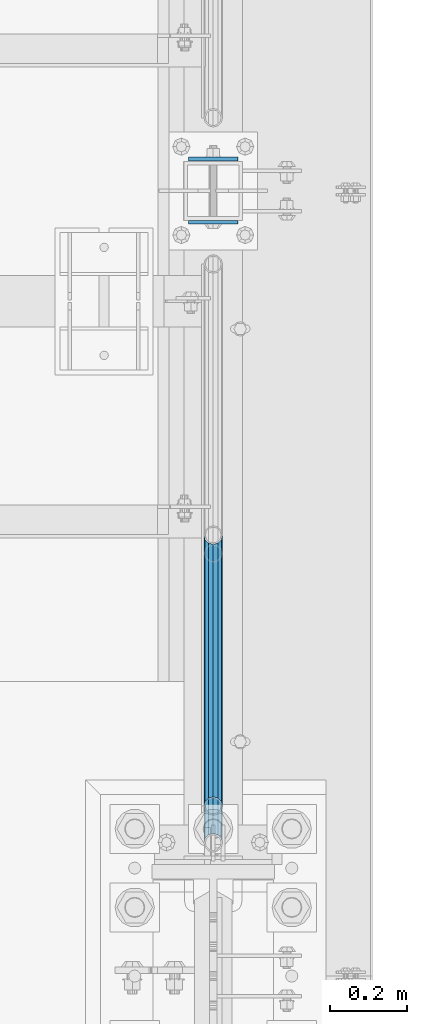
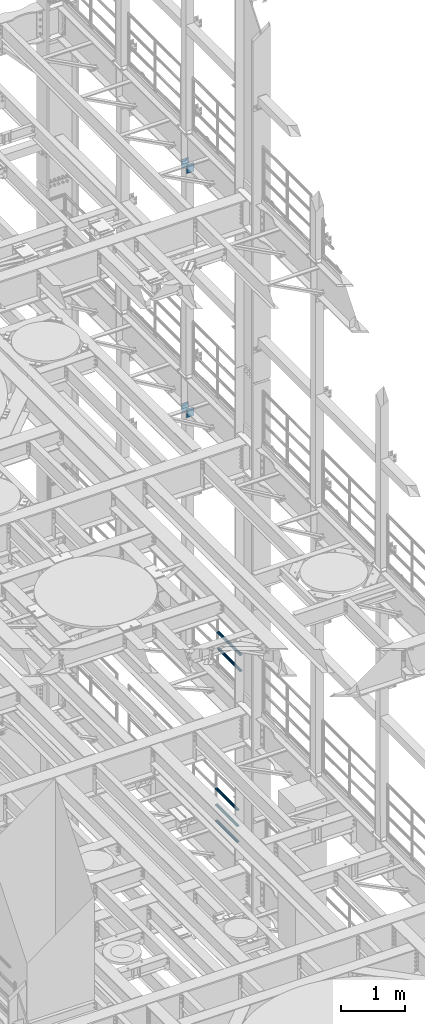
# One storey, part 1342 of 1876: 9 beams, 4 elements without a shape of their own.
"""IFC2X3 building model written with IfcOpenShell, lengths in millimetres."""

from ifc_helpers import new_model, si_unit, frame, origin_with_axes, place, context, subcontext, project, spatial, faceted_brep, material, type_object, element, aggregate, save


model = new_model("IFC2X3")

# Units and contexts
model_context = context("Model", 3, precision=1e-05, world=origin_with_axes())
body_context = subcontext(model_context, "Body", "Model", "MODEL_VIEW")
ifc_project = project(units=[si_unit("LENGTHUNIT", "METRE", prefix="MILLI"), si_unit("AREAUNIT", "SQUARE_METRE"), si_unit("VOLUMEUNIT", "CUBIC_METRE"), si_unit("MASSUNIT", "GRAM", prefix="KILO"), si_unit("TIMEUNIT", "SECOND"), si_unit("PLANEANGLEUNIT", "RADIAN"), si_unit("SOLIDANGLEUNIT", "STERADIAN"), si_unit("THERMODYNAMICTEMPERATUREUNIT", "DEGREE_CELSIUS"), si_unit("LUMINOUSINTENSITYUNIT", "LUMEN")], contexts=[model_context])

# Site, building, storey
site_placement = place(None, origin_with_axes())
site = spatial("IfcSite", under=ifc_project, at=site_placement, CompositionType="ELEMENT")
building_placement = place(site_placement, origin_with_axes())
building = spatial("IfcBuilding", under=site, at=building_placement, Name="Undefined", CompositionType="ELEMENT")
storey_placement = place(building_placement, origin_with_axes())
storey = spatial("IfcBuildingStorey", under=building, at=storey_placement, Name="Undefined", CompositionType="ELEMENT", Elevation=0.0)

# Assembly, beams
assembly_1_placement = place(storey_placement, origin_with_axes())
assembly_1 = element("IfcElementAssembly", 1, at=assembly_1_placement, inside=storey, Name="RAIL", AssemblyPlace="NOTDEFINED", PredefinedType="RIGID_FRAME")
ifc_material_1 = material()
beam_type_1 = type_object("IfcBeamType", Name="PIPE1-1/2SCH40", PredefinedType="NOTDEFINED")
beam_1_placement = place(assembly_1_placement, frame((7620.0, 7964.805, 8620.125), z_axis=(0.0, 0.0, -1.0), x_axis=(0.0, 1.0, 0.0)))
beam_1 = element("IfcBeam", 2, at=beam_1_placement, type_object=beam_type_1, material=ifc_material_1, Name="RAIL", ObjectType="PIPE1-1/2SCH40", context=body_context, shape_type="Brep", body=[
    faceted_brep([(0.0, 24.1299999999992, 0.0), (12.0650000000064, 20.8971929933177, -12.0649999999987), (12.0650000000064, 20.8971929933177, 12.0649999999987), (12.0650000000064, -20.8971929933177, 12.0649999999987), (12.0650000000064, -20.8971929933177, -12.0649999999987), (0.0, -24.1299999999992, 0.0), (20.8971929933249, -12.0650000000005, 20.8971929933177), (20.8971929933249, -12.0650000000005, 15.8661214311796), (15.2545715621445, -17.7076214311801, 10.2235000000001), (12.5151929933249, -20.4470000000001, 0.0), (15.2545715621445, -17.7076214311801, -10.2235000000001), (20.8971929933249, -12.0650000000005, -15.8661214311796), (20.8971929933249, -12.0650000000005, -20.8971929933177), (24.1300000000063, 0.0, -20.4470000000001), (24.1300000000063, 0.0, -24.130000000001), (21.3906214311868, -10.2235000000001, -17.7076214311819), (21.3906214311868, 10.2235000000001, -17.7076214311819), (20.8971929933249, 12.0650000000005, -15.8661214311796), (20.8971929933249, 12.0650000000005, -20.8971929933177), (15.2545715621445, 17.7076214311801, -10.2235000000001), (12.5151929933249, 20.4470000000001, 0.0), (15.2545715621445, 17.7076214311801, 10.2235000000001), (20.8971929933249, 12.0650000000005, 15.8661214311796), (20.8971929933249, 12.0650000000005, 20.8971929933177), (21.3906214311868, 10.2235000000001, 17.7076214311819), (24.1300000000064, 0.0, 20.4470000000001), (24.1300000000064, 0.0, 24.130000000001), (21.3906214311868, -10.2235000000001, 17.7076214311819), (748.982500000002, 24.1300000000001, 0.0), (736.917500000002, 20.8971929933186, -12.0649999999987), (728.085307006683, 12.0649999999996, -20.8971929933177), (748.982500000002, -24.1300000000001, 0.0), (736.917500000002, -20.8971929933186, -12.0649999999987), (736.917500000002, -20.8971929933186, 12.0649999999987), (728.085307006683, -12.0649999999996, 20.8971929933177), (728.085307006683, -12.0649999999996, -20.8971929933177), (724.852500000002, 0.0, -24.130000000001), (727.591878568821, 10.2235000000001, -17.7076214311819), (724.852500000002, 0.0, -20.4470000000001), (728.085307006683, 12.0649999999996, -15.8661214311796), (728.085307006683, -12.0649999999996, -15.8661214311796), (727.591878568821, -10.2235000000001, -17.7076214311819), (733.727928437864, -17.7076214311801, -10.2235000000001), (736.467307006683, -20.4470000000001, 0.0), (733.727928437864, -17.7076214311801, 10.2235000000001), (728.085307006683, -12.0649999999996, 15.8661214311796), (727.591878568821, -10.2235000000001, 17.7076214311819), (724.852500000002, 0.0, 20.4470000000001), (724.852500000002, 0.0, 24.130000000001), (728.085307006683, 12.0649999999996, 20.8971929933177), (736.917500000002, 20.8971929933186, 12.0649999999987), (728.085307006683, 12.0649999999996, 15.8661214311796), (733.727928437864, 17.7076214311801, 10.2235000000001), (736.467307006683, 20.4470000000001, 0.0), (733.727928437864, 17.7076214311801, -10.2235000000001), (727.591878568821, 10.2235000000001, 17.7076214311819)], [[[0, 1, 2]], [[3, 4, 5]], [[6, 7, 8, 9, 10, 11, 12, 4, 3]], [[13, 14, 12, 11, 15]], [[16, 17, 18, 14, 13]], [[2, 1, 18, 17, 19, 20, 21, 22, 23]], [[23, 22, 24, 25, 26]], [[26, 25, 27, 7, 6]], [[1, 0, 28, 29]], [[18, 1, 29, 30]], [[31, 32, 33]], [[6, 3, 33, 34]], [[3, 5, 31, 33]], [[5, 4, 32, 31]], [[4, 12, 35, 32]], [[12, 14, 36, 35]], [[14, 18, 30, 36]], [[37, 38, 36, 30, 39]], [[40, 35, 36, 38, 41]], [[33, 32, 35, 40, 42, 43, 44, 45, 34]], [[34, 45, 46, 47, 48]], [[26, 6, 34, 48]], [[2, 23, 49, 50]], [[23, 26, 48, 49]], [[0, 2, 50, 28]], [[28, 50, 29]], [[49, 51, 52, 53, 54, 39, 30, 29, 50]], [[48, 47, 55, 51, 49]], [[25, 24, 55, 47]], [[55, 24, 22, 21, 52, 51]], [[21, 20, 53, 52]], [[20, 19, 54, 53]], [[19, 17, 16, 37, 39, 54]], [[16, 13, 38, 37]], [[13, 15, 41, 38]], [[41, 15, 11, 10, 42, 40]], [[10, 9, 43, 42]], [[9, 8, 44, 43]], [[8, 7, 27, 46, 45, 44]], [[27, 25, 47, 46]]]),
])
beam_2_placement = place(assembly_1_placement, frame((7620.0, 7964.805, 8924.925), z_axis=(0.0, 0.0, -1.0), x_axis=(0.0, 1.0, 0.0)))
beam_2 = element("IfcBeam", 3, at=beam_2_placement, type_object=beam_type_1, material=ifc_material_1, Name="RAIL", ObjectType="PIPE1-1/2SCH40", context=body_context, shape_type="Brep", body=[
    faceted_brep([(0.0, 24.1299999999992, 0.0), (12.0650000000064, 20.8971929933177, -12.0649999999987), (12.0650000000064, 20.8971929933177, 12.0649999999987), (12.0650000000064, -20.8971929933177, 12.0649999999987), (12.0650000000064, -20.8971929933177, -12.0649999999987), (0.0, -24.1299999999992, 0.0), (20.8971929933249, -12.0650000000005, 20.8971929933177), (20.8971929933249, -12.0650000000005, 15.8661214311796), (15.2545715621445, -17.7076214311801, 10.2235000000001), (12.5151929933249, -20.4470000000001, 0.0), (15.2545715621445, -17.7076214311801, -10.2235000000001), (20.8971929933249, -12.0650000000005, -15.8661214311796), (20.8971929933249, -12.0650000000005, -20.8971929933177), (24.1300000000063, 0.0, -20.4470000000001), (24.1300000000063, 0.0, -24.130000000001), (21.3906214311868, -10.2235000000001, -17.7076214311819), (21.3906214311868, 10.2235000000001, -17.7076214311819), (20.8971929933249, 12.0650000000005, -15.8661214311796), (20.8971929933249, 12.0650000000005, -20.8971929933177), (15.2545715621445, 17.7076214311801, -10.2235000000001), (12.5151929933249, 20.4470000000001, 0.0), (15.2545715621445, 17.7076214311801, 10.2235000000001), (20.8971929933249, 12.0650000000005, 15.8661214311796), (20.8971929933249, 12.0650000000005, 20.8971929933177), (21.3906214311868, 10.2235000000001, 17.7076214311819), (24.1300000000064, 0.0, 20.4470000000001), (24.1300000000064, 0.0, 24.130000000001), (21.3906214311868, -10.2235000000001, 17.7076214311819), (748.982500000002, 24.1300000000001, 0.0), (736.917500000002, 20.8971929933186, -12.0649999999987), (728.085307006683, 12.0649999999996, -20.8971929933177), (748.982500000002, -24.1300000000001, 0.0), (736.917500000002, -20.8971929933186, -12.0649999999987), (736.917500000002, -20.8971929933186, 12.0649999999987), (728.085307006683, -12.0649999999996, 20.8971929933177), (728.085307006683, -12.0649999999996, -20.8971929933177), (724.852500000002, 0.0, -24.130000000001), (727.591878568821, 10.2235000000001, -17.7076214311819), (724.852500000002, 0.0, -20.4470000000001), (728.085307006683, 12.0649999999996, -15.8661214311796), (728.085307006683, -12.0649999999996, -15.8661214311796), (727.591878568821, -10.2235000000001, -17.7076214311819), (733.727928437864, -17.7076214311801, -10.2235000000001), (736.467307006683, -20.4470000000001, 0.0), (733.727928437864, -17.7076214311801, 10.2235000000001), (728.085307006683, -12.0649999999996, 15.8661214311796), (727.591878568821, -10.2235000000001, 17.7076214311819), (724.852500000002, 0.0, 20.4470000000001), (724.852500000002, 0.0, 24.130000000001), (728.085307006683, 12.0649999999996, 20.8971929933177), (736.917500000002, 20.8971929933186, 12.0649999999987), (728.085307006683, 12.0649999999996, 15.8661214311796), (733.727928437864, 17.7076214311801, 10.2235000000001), (736.467307006683, 20.4470000000001, 0.0), (733.727928437864, 17.7076214311801, -10.2235000000001), (727.591878568821, 10.2235000000001, 17.7076214311819)], [[[0, 1, 2]], [[3, 4, 5]], [[6, 7, 8, 9, 10, 11, 12, 4, 3]], [[13, 14, 12, 11, 15]], [[16, 17, 18, 14, 13]], [[2, 1, 18, 17, 19, 20, 21, 22, 23]], [[23, 22, 24, 25, 26]], [[26, 25, 27, 7, 6]], [[1, 0, 28, 29]], [[18, 1, 29, 30]], [[31, 32, 33]], [[6, 3, 33, 34]], [[3, 5, 31, 33]], [[5, 4, 32, 31]], [[4, 12, 35, 32]], [[12, 14, 36, 35]], [[14, 18, 30, 36]], [[37, 38, 36, 30, 39]], [[40, 35, 36, 38, 41]], [[33, 32, 35, 40, 42, 43, 44, 45, 34]], [[34, 45, 46, 47, 48]], [[26, 6, 34, 48]], [[2, 23, 49, 50]], [[23, 26, 48, 49]], [[0, 2, 50, 28]], [[28, 50, 29]], [[49, 51, 52, 53, 54, 39, 30, 29, 50]], [[48, 47, 55, 51, 49]], [[25, 24, 55, 47]], [[55, 24, 22, 21, 52, 51]], [[21, 20, 53, 52]], [[20, 19, 54, 53]], [[19, 17, 16, 37, 39, 54]], [[16, 13, 38, 37]], [[13, 15, 41, 38]], [[41, 15, 11, 10, 42, 40]], [[10, 9, 43, 42]], [[9, 8, 44, 43]], [[8, 7, 27, 46, 45, 44]], [[27, 25, 47, 46]]]),
])
aggregate(assembly_1, [beam_1, beam_2])

assembly_2_placement = place(storey_placement, origin_with_axes())
assembly_2 = element("IfcElementAssembly", 4, at=assembly_2_placement, inside=storey, Name="RAIL", AssemblyPlace="NOTDEFINED", PredefinedType="RIGID_FRAME")
beam_3_placement = place(assembly_2_placement, frame((7620.0, 8761.41249999999, 5292.725), z_axis=(0.0, 0.0, 1.0), x_axis=(0.0, -1.0, 0.0)))
beam_3 = element("IfcBeam", 5, at=beam_3_placement, type_object=beam_type_1, material=ifc_material_1, Name="RAIL", ObjectType="PIPE1-1/2SCH40", context=body_context, shape_type="Brep", body=[
    faceted_brep([(680.460307006681, -12.0649999999996, 20.8971929933186), (680.460307006681, -12.0649999999914, 15.8661214311887), (679.966878568822, -10.2235000000001, 17.7076214311801), (677.2275, 0.0, 20.4470000000001), (677.2275, 0.0, 24.1300000000001), (679.966878568817, 10.2235000000001, 17.7076214311801), (680.460307006681, 12.0650000000078, 15.8661214311724), (680.460307006681, 12.0649999999996, 20.8971929933186), (701.3575, 24.1300000000001, 0.0), (689.2925, 20.8971929933186, 12.0649999999996), (689.2925, 20.8971929933186, -12.0649999999996), (686.102928437854, 17.7076214311801, 10.2235000000001), (688.842307006673, 20.4470000000001, 0.0), (686.102928437854, 17.7076214311801, -10.2235000000001), (680.460307006681, 12.0650000000078, -15.8661214311724), (680.460307006681, 12.0649999999996, -20.8971929933186), (679.966878568817, 10.2235000000001, -17.7076214311801), (677.2275, 0.0, -20.4470000000001), (677.2275, 0.0, -24.1300000000001), (680.460307006681, -12.0649999999914, -15.8661214311887), (680.460307006681, -12.0649999999996, -20.8971929933186), (679.966878568822, -10.2235000000001, -17.7076214311801), (701.3575, -24.1299999999919, 0.0), (689.2925, -20.8971929933186, -12.0649999999996), (689.2925, -20.8971929933186, 12.0649999999996), (686.10292843787, -17.7076214311801, -10.2235000000001), (688.842307006689, -20.4470000000001, 0.0), (686.10292843787, -17.7076214311801, 10.2235000000001), (12.0650000000064, -20.8971929933177, -12.0649999999987), (20.8971929933249, -12.0650000000005, -20.8971929933177), (0.0, 24.1299999999992, 0.0), (12.0650000000064, 20.8971929933177, -12.0649999999987), (12.0650000000064, 20.8971929933177, 12.0649999999987), (20.8971929933249, 12.0650000000005, 20.8971929933177), (24.1300000000064, 0.0, 24.130000000001), (20.8971929933249, 12.0650000000005, -20.8971929933177), (24.1300000000063, 0.0, -24.130000000001), (24.1300000000063, 0.0, -20.4470000000001), (20.8971929933249, -12.0650000000005, -15.8661214311796), (21.3906214311868, -10.2235000000001, -17.7076214311819), (21.3906214311868, 10.2235000000001, -17.7076214311819), (20.8971929933249, 12.0650000000005, -15.8661214311796), (15.2545715621445, 17.7076214311801, -10.2235000000001), (12.5151929933249, 20.4470000000001, 0.0), (15.2545715621445, 17.7076214311801, 10.2235000000001), (20.8971929933249, 12.0650000000005, 15.8661214311796), (21.3906214311868, 10.2235000000001, 17.7076214311819), (24.1300000000064, 0.0, 20.4470000000001), (21.3906214311868, -10.2235000000001, 17.7076214311819), (20.8971929933249, -12.0650000000005, 15.8661214311796), (20.8971929933249, -12.0650000000005, 20.8971929933177), (12.0650000000064, -20.8971929933177, 12.0649999999987), (0.0, -24.1299999999992, 0.0), (15.2545715621445, -17.7076214311801, 10.2235000000001), (12.5151929933249, -20.4470000000001, 0.0), (15.2545715621445, -17.7076214311801, -10.2235000000001)], [[[0, 1, 2, 3, 4]], [[4, 3, 5, 6, 7]], [[8, 9, 10]], [[7, 6, 11, 12, 13, 14, 15, 10, 9]], [[16, 17, 18, 15, 14]], [[19, 20, 18, 17, 21]], [[22, 23, 24]], [[24, 23, 20, 19, 25, 26, 27, 1, 0]], [[28, 29, 20, 23]], [[30, 31, 32]], [[33, 34, 4, 7]], [[32, 33, 7, 9]], [[30, 32, 9, 8]], [[31, 30, 8, 10]], [[35, 31, 10, 15]], [[36, 35, 15, 18]], [[29, 36, 18, 20]], [[37, 36, 29, 38, 39]], [[40, 41, 35, 36, 37]], [[32, 31, 35, 41, 42, 43, 44, 45, 33]], [[33, 45, 46, 47, 34]], [[34, 47, 48, 49, 50]], [[34, 50, 0, 4]], [[50, 51, 24, 0]], [[51, 52, 22, 24]], [[52, 28, 23, 22]], [[51, 28, 52]], [[50, 49, 53, 54, 55, 38, 29, 28, 51]], [[55, 54, 26, 25]], [[21, 39, 38, 55, 25, 19]], [[37, 39, 21, 17]], [[40, 37, 17, 16]], [[42, 41, 40, 16, 14, 13]], [[43, 42, 13, 12]], [[44, 43, 12, 11]], [[5, 46, 45, 44, 11, 6]], [[47, 46, 5, 3]], [[48, 47, 3, 2]], [[53, 49, 48, 2, 1, 27]], [[54, 53, 27, 26]]]),
])
beam_4_placement = place(assembly_2_placement, frame((7620.0, 8060.055, 5597.525), z_axis=(0.0, 0.0, -1.0), x_axis=(0.0, 1.0, 0.0)))
beam_4 = element("IfcBeam", 6, at=beam_4_placement, type_object=beam_type_1, material=ifc_material_1, Name="RAIL", ObjectType="PIPE1-1/2SCH40", context=body_context, shape_type="Brep", body=[
    faceted_brep([(0.0, 24.1299999999992, 0.0), (12.0650000000064, 20.8971929933177, -12.0649999999987), (12.0650000000064, 20.8971929933177, 12.0649999999987), (12.0650000000064, -20.8971929933177, 12.0649999999987), (12.0650000000064, -20.8971929933177, -12.0649999999987), (0.0, -24.1299999999992, 0.0), (20.8971929933249, -12.0650000000005, 20.8971929933177), (20.8971929933249, -12.0650000000005, 15.8661214311796), (15.2545715621445, -17.7076214311801, 10.2235000000001), (12.5151929933249, -20.4470000000001, 0.0), (15.2545715621445, -17.7076214311801, -10.2235000000001), (20.8971929933249, -12.0650000000005, -15.8661214311796), (20.8971929933249, -12.0650000000005, -20.8971929933177), (24.1300000000063, 0.0, -20.4470000000001), (24.1300000000063, 0.0, -24.130000000001), (21.3906214311868, -10.2235000000001, -17.7076214311819), (21.3906214311868, 10.2235000000001, -17.7076214311819), (20.8971929933249, 12.0650000000005, -15.8661214311796), (20.8971929933249, 12.0650000000005, -20.8971929933177), (15.2545715621445, 17.7076214311801, -10.2235000000001), (12.5151929933249, 20.4470000000001, 0.0), (15.2545715621445, 17.7076214311801, 10.2235000000001), (20.8971929933249, 12.0650000000005, 15.8661214311796), (20.8971929933249, 12.0650000000005, 20.8971929933177), (21.3906214311868, 10.2235000000001, 17.7076214311819), (24.1300000000064, 0.0, 20.4470000000001), (24.1300000000064, 0.0, 24.130000000001), (21.3906214311868, -10.2235000000001, 17.7076214311819), (701.3575, 24.1300000000001, 0.0), (689.2925, 20.8971929933186, -12.0649999999996), (680.460307006681, 12.0649999999996, -20.8971929933186), (701.3575, -24.1299999999919, 0.0), (689.2925, -20.8971929933186, -12.0649999999996), (689.2925, -20.8971929933186, 12.0649999999996), (680.460307006681, -12.0649999999996, 20.8971929933186), (680.460307006681, -12.0649999999996, -20.8971929933186), (677.2275, 0.0, -24.1300000000001), (679.966878568817, 10.2235000000001, -17.7076214311801), (677.2275, 0.0, -20.4470000000001), (680.460307006681, 12.0650000000078, -15.8661214311724), (680.460307006681, -12.0649999999914, -15.8661214311887), (679.966878568822, -10.2235000000001, -17.7076214311801), (686.10292843787, -17.7076214311801, -10.2235000000001), (688.842307006689, -20.4470000000001, 0.0), (686.10292843787, -17.7076214311801, 10.2235000000001), (680.460307006681, -12.0649999999914, 15.8661214311887), (679.966878568822, -10.2235000000001, 17.7076214311801), (677.2275, 0.0, 20.4470000000001), (677.2275, 0.0, 24.1300000000001), (680.460307006681, 12.0649999999996, 20.8971929933186), (689.2925, 20.8971929933186, 12.0649999999996), (680.460307006681, 12.0650000000078, 15.8661214311724), (686.102928437854, 17.7076214311801, 10.2235000000001), (688.842307006673, 20.4470000000001, 0.0), (686.102928437854, 17.7076214311801, -10.2235000000001), (679.966878568817, 10.2235000000001, 17.7076214311801)], [[[0, 1, 2]], [[3, 4, 5]], [[6, 7, 8, 9, 10, 11, 12, 4, 3]], [[13, 14, 12, 11, 15]], [[16, 17, 18, 14, 13]], [[2, 1, 18, 17, 19, 20, 21, 22, 23]], [[23, 22, 24, 25, 26]], [[26, 25, 27, 7, 6]], [[1, 0, 28, 29]], [[18, 1, 29, 30]], [[31, 32, 33]], [[6, 3, 33, 34]], [[3, 5, 31, 33]], [[5, 4, 32, 31]], [[4, 12, 35, 32]], [[12, 14, 36, 35]], [[14, 18, 30, 36]], [[37, 38, 36, 30, 39]], [[40, 35, 36, 38, 41]], [[33, 32, 35, 40, 42, 43, 44, 45, 34]], [[34, 45, 46, 47, 48]], [[26, 6, 34, 48]], [[2, 23, 49, 50]], [[23, 26, 48, 49]], [[0, 2, 50, 28]], [[28, 50, 29]], [[49, 51, 52, 53, 54, 39, 30, 29, 50]], [[48, 47, 55, 51, 49]], [[25, 24, 55, 47]], [[55, 24, 22, 21, 52, 51]], [[21, 20, 53, 52]], [[20, 19, 54, 53]], [[19, 17, 16, 37, 39, 54]], [[16, 13, 38, 37]], [[13, 15, 41, 38]], [[41, 15, 11, 10, 42, 40]], [[10, 9, 43, 42]], [[9, 8, 44, 43]], [[8, 7, 27, 46, 45, 44]], [[27, 25, 47, 46]]]),
])
beam_5_placement = place(assembly_2_placement, frame((7620.0, 8060.055, 5902.325), z_axis=(0.0, 0.0, -1.0), x_axis=(0.0, 1.0, 0.0)))
beam_5 = element("IfcBeam", 7, at=beam_5_placement, type_object=beam_type_1, material=ifc_material_1, Name="RAIL", ObjectType="PIPE1-1/2SCH40", context=body_context, shape_type="Brep", body=[
    faceted_brep([(0.0, 24.1299999999992, 0.0), (12.0650000000064, 20.8971929933177, -12.0649999999987), (12.0650000000064, 20.8971929933177, 12.0649999999987), (12.0650000000064, -20.8971929933177, 12.0649999999987), (12.0650000000064, -20.8971929933177, -12.0649999999987), (0.0, -24.1299999999992, 0.0), (20.8971929933249, -12.0650000000005, 20.8971929933177), (20.8971929933249, -12.0650000000005, 15.8661214311796), (15.2545715621445, -17.7076214311801, 10.2235000000001), (12.5151929933249, -20.4470000000001, 0.0), (15.2545715621445, -17.7076214311801, -10.2235000000001), (20.8971929933249, -12.0650000000005, -15.8661214311796), (20.8971929933249, -12.0650000000005, -20.8971929933177), (24.1300000000063, 0.0, -20.4470000000001), (24.1300000000063, 0.0, -24.130000000001), (21.3906214311868, -10.2235000000001, -17.7076214311819), (21.3906214311868, 10.2235000000001, -17.7076214311819), (20.8971929933249, 12.0650000000005, -15.8661214311796), (20.8971929933249, 12.0650000000005, -20.8971929933177), (15.2545715621445, 17.7076214311801, -10.2235000000001), (12.5151929933249, 20.4470000000001, 0.0), (15.2545715621445, 17.7076214311801, 10.2235000000001), (20.8971929933249, 12.0650000000005, 15.8661214311796), (20.8971929933249, 12.0650000000005, 20.8971929933177), (21.3906214311868, 10.2235000000001, 17.7076214311819), (24.1300000000064, 0.0, 20.4470000000001), (24.1300000000064, 0.0, 24.130000000001), (21.3906214311868, -10.2235000000001, 17.7076214311819), (701.3575, 24.1300000000001, 0.0), (689.2925, 20.8971929933186, -12.0649999999996), (680.460307006681, 12.0649999999996, -20.8971929933186), (701.3575, -24.1299999999919, 0.0), (689.2925, -20.8971929933186, -12.0649999999996), (689.2925, -20.8971929933186, 12.0649999999996), (680.460307006681, -12.0649999999996, 20.8971929933186), (680.460307006681, -12.0649999999996, -20.8971929933186), (677.2275, 0.0, -24.1300000000001), (679.966878568817, 10.2235000000001, -17.7076214311801), (677.2275, 0.0, -20.4470000000001), (680.460307006681, 12.0650000000078, -15.8661214311724), (680.460307006681, -12.0649999999914, -15.8661214311887), (679.966878568822, -10.2235000000001, -17.7076214311801), (686.10292843787, -17.7076214311801, -10.2235000000001), (688.842307006689, -20.4470000000001, 0.0), (686.10292843787, -17.7076214311801, 10.2235000000001), (680.460307006681, -12.0649999999914, 15.8661214311887), (679.966878568822, -10.2235000000001, 17.7076214311801), (677.2275, 0.0, 20.4470000000001), (677.2275, 0.0, 24.1300000000001), (680.460307006681, 12.0649999999996, 20.8971929933186), (689.2925, 20.8971929933186, 12.0649999999996), (680.460307006681, 12.0650000000078, 15.8661214311724), (686.102928437854, 17.7076214311801, 10.2235000000001), (688.842307006673, 20.4470000000001, 0.0), (686.102928437854, 17.7076214311801, -10.2235000000001), (679.966878568817, 10.2235000000001, 17.7076214311801)], [[[0, 1, 2]], [[3, 4, 5]], [[6, 7, 8, 9, 10, 11, 12, 4, 3]], [[13, 14, 12, 11, 15]], [[16, 17, 18, 14, 13]], [[2, 1, 18, 17, 19, 20, 21, 22, 23]], [[23, 22, 24, 25, 26]], [[26, 25, 27, 7, 6]], [[1, 0, 28, 29]], [[18, 1, 29, 30]], [[31, 32, 33]], [[6, 3, 33, 34]], [[3, 5, 31, 33]], [[5, 4, 32, 31]], [[4, 12, 35, 32]], [[12, 14, 36, 35]], [[14, 18, 30, 36]], [[37, 38, 36, 30, 39]], [[40, 35, 36, 38, 41]], [[33, 32, 35, 40, 42, 43, 44, 45, 34]], [[34, 45, 46, 47, 48]], [[26, 6, 34, 48]], [[2, 23, 49, 50]], [[23, 26, 48, 49]], [[0, 2, 50, 28]], [[28, 50, 29]], [[49, 51, 52, 53, 54, 39, 30, 29, 50]], [[48, 47, 55, 51, 49]], [[25, 24, 55, 47]], [[55, 24, 22, 21, 52, 51]], [[21, 20, 53, 52]], [[20, 19, 54, 53]], [[19, 17, 16, 37, 39, 54]], [[16, 13, 38, 37]], [[13, 15, 41, 38]], [[41, 15, 11, 10, 42, 40]], [[10, 9, 43, 42]], [[9, 8, 44, 43]], [[8, 7, 27, 46, 45, 44]], [[27, 25, 47, 46]]]),
])
aggregate(assembly_2, [beam_3, beam_4, beam_5])

assembly_3_placement = place(storey_placement, origin_with_axes())
assembly_3 = element("IfcElementAssembly", 8, at=assembly_3_placement, inside=storey, Name="BEAM", AssemblyPlace="NOTDEFINED", PredefinedType="RIGID_FRAME")
ifc_material_2 = material(Name="STEEL/A36")
beam_type_2 = type_object("IfcBeamType", PredefinedType="NOTDEFINED")
beam_6_placement = place(assembly_3_placement, frame((7556.36848042001, 9734.55, 12604.7488224823), z_axis=(2.95459999824743e-05, 0.0, -0.999999999563517), x_axis=(0.999999999563517, 0.0, 2.95459999828704e-05)))
beam_6 = element("IfcBeam", 9, at=beam_6_placement, type_object=beam_type_2, material=ifc_material_2, Name="PLATE", context=body_context, shape_type="Brep", body=[
    faceted_brep([(0.0, 4.76249999999982, -82.5499999999993), (0.0, 4.76249999999982, 82.5499999999993), (127.0, 4.76249999999982, 82.5499999999993), (127.0, 4.76249999999982, -82.5499999999993), (0.0, -4.76249999999982, 82.5499999999993), (127.0, -4.76249999999982, 82.5499999999993), (0.0, -4.76249999999982, -82.5499999999993), (127.0, -4.76249999999982, -82.5499999999993)], [[[0, 1, 2, 3]], [[1, 4, 5, 2]], [[4, 6, 7, 5]], [[6, 0, 3, 7]], [[5, 7, 3, 2]], [[6, 4, 1, 0]]]),
])
beam_7_placement = place(assembly_3_placement, frame((7556.36848042001, 9571.0375, 12604.7488224823), z_axis=(2.95459999824743e-05, 0.0, -0.999999999563517), x_axis=(0.999999999563517, 0.0, 2.95459999828704e-05)))
beam_7 = element("IfcBeam", 10, at=beam_7_placement, type_object=beam_type_2, material=ifc_material_2, Name="PLATE", context=body_context, shape_type="Brep", body=[
    faceted_brep([(0.0, 4.76249999999982, -82.5499999999993), (0.0, 4.76249999999982, 82.5499999999993), (127.0, 4.76249999999982, 82.5499999999993), (127.0, 4.76249999999982, -82.5499999999993), (0.0, -4.76249999999982, 82.5499999999993), (127.0, -4.76249999999982, 82.5499999999993), (0.0, -4.76249999999982, -82.5499999999993), (127.0, -4.76249999999982, -82.5499999999993)], [[[0, 1, 2, 3]], [[1, 4, 5, 2]], [[4, 6, 7, 5]], [[6, 0, 3, 7]], [[5, 7, 3, 2]], [[6, 4, 1, 0]]]),
])
aggregate(assembly_3, [beam_6, beam_7])

assembly_4_placement = place(storey_placement, origin_with_axes())
assembly_4 = element("IfcElementAssembly", 11, at=assembly_4_placement, inside=storey, Name="BEAM", AssemblyPlace="NOTDEFINED", PredefinedType="RIGID_FRAME")
beam_8_placement = place(assembly_4_placement, frame((7556.5, 9734.55, 17278.35), z_axis=(0.0, 0.0, -1.0), x_axis=(1.0, 0.0, 0.0)))
beam_8 = element("IfcBeam", 12, at=beam_8_placement, type_object=beam_type_2, material=ifc_material_2, Name="PLATE", context=body_context, shape_type="Brep", body=[
    faceted_brep([(0.0, 4.76249999999982, -82.5499999999993), (0.0, 4.76249999999982, 82.5499999999993), (127.0, 4.76249999999982, 82.5499999999993), (127.0, 4.76249999999982, -82.5499999999993), (0.0, -4.76249999999982, 82.5499999999993), (127.0, -4.76249999999982, 82.5499999999993), (0.0, -4.76249999999982, -82.5499999999993), (127.0, -4.76249999999982, -82.5499999999993)], [[[0, 1, 2, 3]], [[1, 4, 5, 2]], [[4, 6, 7, 5]], [[6, 0, 3, 7]], [[5, 7, 3, 2]], [[6, 4, 1, 0]]]),
])
beam_9_placement = place(assembly_4_placement, frame((7556.5, 9571.0375, 17278.35), z_axis=(0.0, 0.0, -1.0), x_axis=(1.0, 0.0, 0.0)))
beam_9 = element("IfcBeam", 13, at=beam_9_placement, type_object=beam_type_2, material=ifc_material_2, Name="PLATE", context=body_context, shape_type="Brep", body=[
    faceted_brep([(0.0, 4.76249999999982, -82.5499999999993), (0.0, 4.76249999999982, 82.5499999999993), (127.0, 4.76249999999982, 82.5499999999993), (127.0, 4.76249999999982, -82.5499999999993), (0.0, -4.76249999999982, 82.5499999999993), (127.0, -4.76249999999982, 82.5499999999993), (0.0, -4.76249999999982, -82.5499999999993), (127.0, -4.76249999999982, -82.5499999999993)], [[[0, 1, 2, 3]], [[1, 4, 5, 2]], [[4, 6, 7, 5]], [[6, 0, 3, 7]], [[5, 7, 3, 2]], [[6, 4, 1, 0]]]),
])
aggregate(assembly_4, [beam_8, beam_9])

save(model, "model.ifc")
